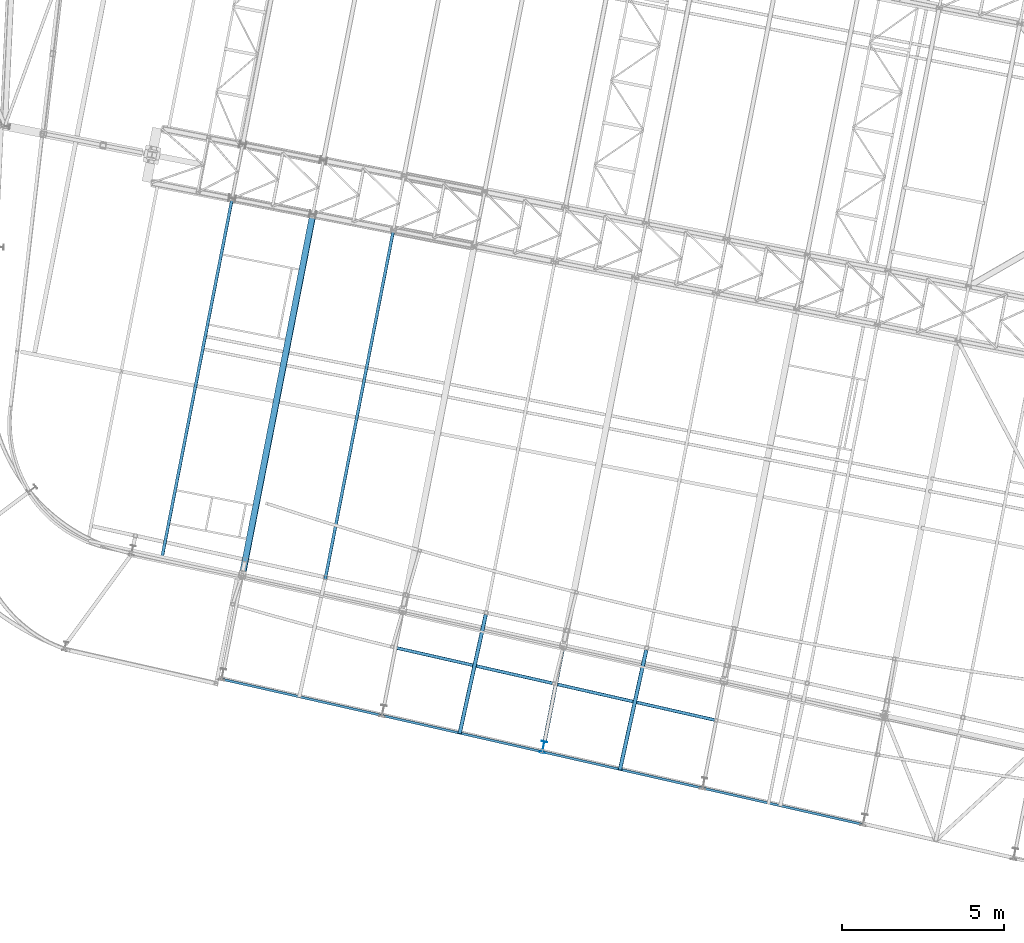
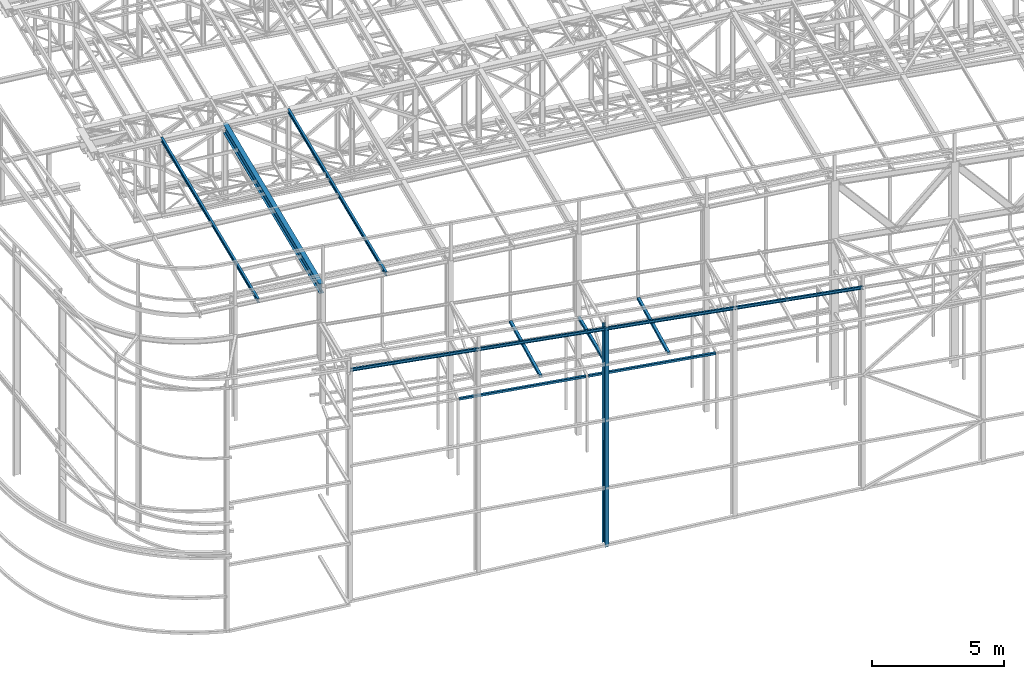
# One storey, part 23 of 215: 10 beams, 10 elements without a shape of their own.
"""IFC2X3 building model written with IfcOpenShell, lengths in millimetres."""

from ifc_helpers import new_model, entity, si_unit, frame, origin_with_axes, origin_2d_with_axis, place, context, subcontext, project, spatial, hollow_rectangle, i_section, extrude, clip, halfspace, material, type_object, element, aggregate, save


model = new_model("IFC2X3")

# Units and contexts
model_context = context("Model", 3, precision=1e-05, world=origin_with_axes())
body_context = subcontext(model_context, "Body", "Model", "MODEL_VIEW")
ifc_project = project(units=[si_unit("LENGTHUNIT", "METRE", prefix="MILLI"), si_unit("AREAUNIT", "SQUARE_METRE"), si_unit("VOLUMEUNIT", "CUBIC_METRE"), si_unit("MASSUNIT", "GRAM", prefix="KILO"), si_unit("TIMEUNIT", "SECOND"), si_unit("PLANEANGLEUNIT", "RADIAN"), si_unit("SOLIDANGLEUNIT", "STERADIAN"), si_unit("THERMODYNAMICTEMPERATUREUNIT", "DEGREE_CELSIUS"), si_unit("LUMINOUSINTENSITYUNIT", "LUMEN")], contexts=[model_context])

# Site, building, storey
site_placement = place(None, origin_with_axes())
site = spatial("IfcSite", under=ifc_project, at=site_placement, CompositionType="ELEMENT")
building_placement = place(site_placement, origin_with_axes())
building = spatial("IfcBuilding", under=site, at=building_placement, Name="Undefined", CompositionType="ELEMENT")
storey_placement = place(building_placement, origin_with_axes())
storey = spatial("IfcBuildingStorey", under=building, at=storey_placement, Name="Undefined", CompositionType="ELEMENT", Elevation=0.0)

# Assembly, beam
assembly_1_placement = place(storey_placement, origin_with_axes())
assembly_1 = element("IfcElementAssembly", 1, at=assembly_1_placement, inside=storey, Name="Steel Assembly", AssemblyPlace="NOTDEFINED", PredefinedType="RIGID_FRAME")
ifc_material = material(Name="STEEL/S275JR")
beam_type_1 = type_object("IfcBeamType", PredefinedType="NOTDEFINED")
beam_1_placement = place(assembly_1_placement, frame((49734.1949357344, 7938.5455283681, 6760.00000147687), z_axis=(0.220972682875029, 0.975279997448431, 0.0), x_axis=(0.975279997448431, -0.220972682875029, 0.0)))
beam_1 = element("IfcBeam", 2, at=beam_1_placement, type_object=beam_type_1, material=ifc_material, Name="POUTRE", context=body_context, shape_type="SweptSolid", body=[
    entity("IfcRevolvedAreaSolid", entity("IfcRectangleHollowProfileDef", "AREA", None, entity("IfcAxis2Placement2D", entity("IfcCartesianPoint", [0.0, 0.0]), entity("IfcDirection", [1.0, 0.0])), 100.0, 100.0, 4.0, 4.0, 8.0), entity("IfcAxis2Placement3D", entity("IfcCartesianPoint", [5031.56023974166, 0.0, -1.39653850698742e-13]), entity("IfcDirection", [-0.999999912093675, 0.0, -0.000419300180813284]), entity("IfcDirection", [-6.93889390390723e-18, -1.0, -3.46944695195361e-18])), entity("IfcAxis1Placement", entity("IfcCartesianPoint", [0.0, 5999950.0, 0.0]), entity("IfcDirection", [-1.0, 0.0, 0.0])), 0.000838600386155836),
])
aggregate(assembly_1, [beam_1])

assembly_2_placement = place(storey_placement, origin_with_axes())
assembly_2 = element("IfcElementAssembly", 3, at=assembly_2_placement, inside=storey, Name="Steel Assembly", AssemblyPlace="NOTDEFINED", PredefinedType="RIGID_FRAME")
beam_2_placement = place(assembly_2_placement, frame((54738.9696780622, 6804.5731319884, 6760.00000147687), z_axis=(0.22097429006788, 0.975279633299597, 0.0), x_axis=(0.975279633299597, -0.220974290067881, 0.0)))
beam_2 = element("IfcBeam", 4, at=beam_2_placement, type_object=beam_type_1, material=ifc_material, Name="POUTRE", context=body_context, shape_type="SweptSolid", body=[
    entity("IfcRevolvedAreaSolid", entity("IfcRectangleHollowProfileDef", "AREA", None, entity("IfcAxis2Placement2D", entity("IfcCartesianPoint", [0.0, 0.0]), entity("IfcDirection", [1.0, 0.0])), 100.0, 100.0, 4.0, 4.0, 8.0), entity("IfcAxis2Placement3D", entity("IfcCartesianPoint", [5053.66926791751, 0.0, -1.40267499502064e-13]), entity("IfcDirection", [-0.999999800467077, 0.0, -0.000631716554946597]), entity("IfcDirection", [-6.93889390390723e-18, -1.0, -3.46944695195361e-18])), entity("IfcAxis1Placement", entity("IfcCartesianPoint", [0.0, 3999950.0, 0.0]), entity("IfcDirection", [-1.0, 0.0, 0.0])), 0.00126343319374317),
])
aggregate(assembly_2, [beam_2])

assembly_3_placement = place(storey_placement, origin_with_axes())
assembly_3 = element("IfcElementAssembly", 5, at=assembly_3_placement, inside=storey, Name="Steel Assembly", AssemblyPlace="NOTDEFINED", PredefinedType="RIGID_FRAME")
beam_type_2 = type_object("IfcBeamType", PredefinedType="NOTDEFINED")
beam_3_placement = place(assembly_3_placement, frame((57551.4930938243, 7859.60198445951, 8706.00018002709), z_axis=(0.976696868550088, -0.214623453901133, -1.0000003380751e-09), x_axis=(-0.214623453901134, -0.976696868550088, 0.0)))
beam_3 = element("IfcBeam", 6, at=beam_3_placement, type_object=beam_type_2, material=ifc_material, Name="LISSE", context=body_context, shape_type="SweptSolid", body=[
    extrude(hollow_rectangle(XDim=120.0, YDim=120.0, WallThickness=5.0, InnerFilletRadius=5.0, OuterFilletRadius=10.0, at=origin_2d_with_axis()), frame((3805.11620215774, 0.0, 1.05613190475244e-13), z_axis=(-1.0, 0.0, 0.0), x_axis=(-6.93889390390723e-18, -1.0, -3.46944695195361e-18)), (0.0, 0.0, 1.0), 3805.1),
])
aggregate(assembly_3, [beam_3])

assembly_4_placement = place(storey_placement, origin_with_axes())
assembly_4 = element("IfcElementAssembly", 7, at=assembly_4_placement, inside=storey, Name="Steel Assembly", AssemblyPlace="NOTDEFINED", PredefinedType="RIGID_FRAME")
beam_4_placement = place(assembly_4_placement, frame((52582.3981010714, 8951.08159722685, 8706.00018681917), z_axis=(0.976696868550088, -0.214623453901133, -1.0000003380751e-09), x_axis=(-0.214623453901134, -0.976696868550088, 0.0)))
beam_4 = element("IfcBeam", 8, at=beam_4_placement, type_object=beam_type_2, material=ifc_material, Name="LISSE", context=body_context, shape_type="SweptSolid", body=[
    extrude(hollow_rectangle(XDim=120.0, YDim=120.0, WallThickness=5.0, InnerFilletRadius=5.0, OuterFilletRadius=10.0, at=origin_2d_with_axis()), frame((3771.67735109101, 0.0, 0.0), z_axis=(-1.0, 0.0, 0.0), x_axis=(-6.93889390390723e-18, -1.0, -3.46944695195361e-18)), (0.0, 0.0, 1.0), 3771.7),
])
aggregate(assembly_4, [beam_4])

assembly_5_placement = place(storey_placement, origin_with_axes())
assembly_5 = element("IfcElementAssembly", 9, at=assembly_5_placement, inside=storey, Name="Steel Assembly", AssemblyPlace="NOTDEFINED", PredefinedType="RIGID_FRAME")
beam_5_placement = place(assembly_5_placement, frame((54966.4548799804, 7900.8001297589, 8710.00002363711), z_axis=(0.0, 0.0, 1.0), x_axis=(-0.191859508000518, -0.981422401002646, -1.00000033853845e-09)))
beam_5 = element("IfcBeam", 10, at=beam_5_placement, type_object=beam_type_2, material=ifc_material, Name="POUTRE", context=body_context, shape_type="SweptSolid", body=[
    extrude(hollow_rectangle(XDim=120.0, YDim=120.0, WallThickness=5.0, InnerFilletRadius=5.0, OuterFilletRadius=10.0, at=origin_2d_with_axis()), frame((2933.14518294702, 5.62751907443717e-16, 6.0656020728427e-22), z_axis=(-1.0, 0.0, 0.0), x_axis=(-6.93889390390723e-18, -1.0, -3.46944695195361e-18)), (0.0, 0.0, 1.0), 2933.1),
])
aggregate(assembly_5, [beam_5])

assembly_6_placement = place(storey_placement, origin_with_axes())
assembly_6 = element("IfcElementAssembly", 11, at=assembly_6_placement, inside=storey, Name="Steel Assembly", AssemblyPlace="NOTDEFINED", PredefinedType="RIGID_FRAME")
beam_type_3 = type_object("IfcBeamType", Name="IPE180", PredefinedType="NOTDEFINED")
beam_6_placement = place(assembly_6_placement, frame((47534.1641841107, 9638.6435989969, 12277.9429806952), z_axis=(-0.0304080349967745, 0.00594450299936818, 0.999519891893966), x_axis=(0.191859470081235, 0.981422408415534, 0.0)))
beam_6 = element("IfcBeam", 12, at=beam_6_placement, type_object=beam_type_3, material=ifc_material, ObjectType="IPE180", context=body_context, shape_type="SweptSolid", body=[
    extrude(i_section(OverallWidth=91.0, OverallDepth=180.0, WebThickness=5.300000191, FlangeThickness=8.0, FilletRadius=9.0, at=origin_2d_with_axis()), frame((11424.3348480152, -1.46234879802264e-11, 1.81829380171976e-12), z_axis=(-1.0, 0.0, 0.0), x_axis=(-6.93889390390723e-18, -1.0, -3.46944695195361e-18)), (0.0, 0.0, 1.0), 11424.3),
])
aggregate(assembly_6, [beam_6])

assembly_7_placement = place(storey_placement, origin_with_axes())
assembly_7 = element("IfcElementAssembly", 13, at=assembly_7_placement, inside=storey, Name="Steel Assembly", AssemblyPlace="NOTDEFINED", PredefinedType="RIGID_FRAME")
beam_7_placement = place(assembly_7_placement, frame((42563.8884250742, 10728.0458335916, 12120.2549981609), z_axis=(-0.0304080349967745, 0.00594450299936818, 0.999519891893966), x_axis=(0.191859470081235, 0.981422408415534, 0.0)))
beam_7 = element("IfcBeam", 14, at=beam_7_placement, type_object=beam_type_3, material=ifc_material, ObjectType="IPE180", context=body_context, shape_type="SweptSolid", body=[
    extrude(i_section(OverallWidth=91.0, OverallDepth=180.0, WebThickness=5.300000191, FlangeThickness=8.0, FilletRadius=9.0, at=origin_2d_with_axis()), frame((11308.7655925911, -6.38099879331386e-14, -1.82114243137542e-12), z_axis=(-1.0, 0.0, 0.0), x_axis=(-6.93889390390723e-18, -1.0, -3.46944695195361e-18)), (0.0, 0.0, 1.0), 11308.8),
])
aggregate(assembly_7, [beam_7])

assembly_8_placement = place(storey_placement, origin_with_axes())
assembly_8 = element("IfcElementAssembly", 15, at=assembly_8_placement, inside=storey, Name="Steel Assembly", AssemblyPlace="NOTDEFINED", PredefinedType="RIGID_FRAME")
beam_type_4 = type_object("IfcBeamType", Name="IPE360", PredefinedType="NOTDEFINED")
beam_8_placement = place(assembly_8_placement, frame((54363.332301515, 4846.63061380984, 10433.171658126), z_axis=(0.191859470081235, 0.981422408415534, 0.0), x_axis=(0.0, 0.0, -1.0)))
beam_8 = element("IfcBeam", 16, at=beam_8_placement, type_object=beam_type_4, material=ifc_material, Name="MONTANT", ObjectType="IPE360", context=body_context, shape_type="Clipping", body=[
    clip(extrude(i_section(OverallWidth=170.0, OverallDepth=360.0, WebThickness=8.0, FlangeThickness=12.69999981, FilletRadius=18.0, at=origin_2d_with_axis()), frame((10165.2787800281, 0.0, -1.81898940354586e-12), z_axis=(-1.0, 0.0, 0.0), x_axis=(-6.93889390390723e-18, -1.0, -3.46944695195361e-18)), (0.0, 0.0, 1.0), 10165.3), halfspace(frame((10167.0175501737, 146.196694109065, -628.260262628246), z_axis=(-0.998850991769565, 0.0479026806605242, 0.0014245794090564), x_axis=(-1.0230287445127e-09, -0.0297259118404429, 0.999558087439271)), True)),
])
aggregate(assembly_8, [beam_8])

assembly_9_placement = place(storey_placement, origin_with_axes())
assembly_9 = element("IfcElementAssembly", 17, at=assembly_9_placement, inside=storey, Name="Steel Assembly", AssemblyPlace="NOTDEFINED", PredefinedType="RIGID_FRAME")
beam_type_5 = type_object("IfcBeamType", Name="IPE140", PredefinedType="NOTDEFINED")
beam_9_placement = place(assembly_9_placement, frame((44408.1560124724, 6952.44211020024, 10566.389264607), z_axis=(-0.0193731289925456, 0.00438949999831131, -0.999802687615313), x_axis=(0.97508690267699, -0.220931994926813, -0.0198641849934198)))
beam_9 = element("IfcBeam", 18, at=beam_9_placement, type_object=beam_type_5, material=ifc_material, Name="LISSE", ObjectType="IPE140", context=body_context, shape_type="SweptSolid", body=[
    extrude(i_section(OverallWidth=73.0, OverallDepth=140.0, WebThickness=4.699999809, FlangeThickness=6.900000095, FilletRadius=7.0, at=origin_2d_with_axis()), frame((20360.8281449873, 3.73625156193429e-12, 0.0), z_axis=(-1.0, 0.0, 0.0), x_axis=(-6.93889390390723e-18, -1.0, -3.46944695195361e-18)), (0.0, 0.0, 1.0), 20360.8),
])
aggregate(assembly_9, [beam_9])

assembly_10_placement = place(storey_placement, origin_with_axes())
assembly_10 = element("IfcElementAssembly", 19, at=assembly_10_placement, inside=storey, Name="Steel Assembly", AssemblyPlace="NOTDEFINED", PredefinedType="RIGID_FRAME")
beam_type_6 = type_object("IfcBeamType", Name="IPE450", PredefinedType="NOTDEFINED")
beam_10_placement = place(assembly_10_placement, frame((47233.9105030167, 21337.9254086784, 12062.0714123761), z_axis=(-0.0304080349967745, 0.00594450299936818, 0.999519891893966), x_axis=(-0.191859508000518, -0.981422401002646, -1.00000033853845e-09)))
beam_10 = element("IfcBeam", 20, at=beam_10_placement, type_object=beam_type_6, material=ifc_material, Name="POUTRE", ObjectType="IPE450", context=body_context, shape_type="SweptSolid", body=[
    extrude(i_section(OverallWidth=190.0, OverallDepth=450.0, WebThickness=9.399999619, FlangeThickness=14.60000038, FilletRadius=21.0, at=origin_2d_with_axis()), frame((11248.2044284253, 1.83027052388154e-13, -7.99475409584937e-15), z_axis=(-1.0, 0.0, 0.0), x_axis=(-6.93889390390723e-18, -1.0, -3.46944695195361e-18)), (0.0, 0.0, 1.0), 11248.2),
])
aggregate(assembly_10, [beam_10])

save(model, "model.ifc")
